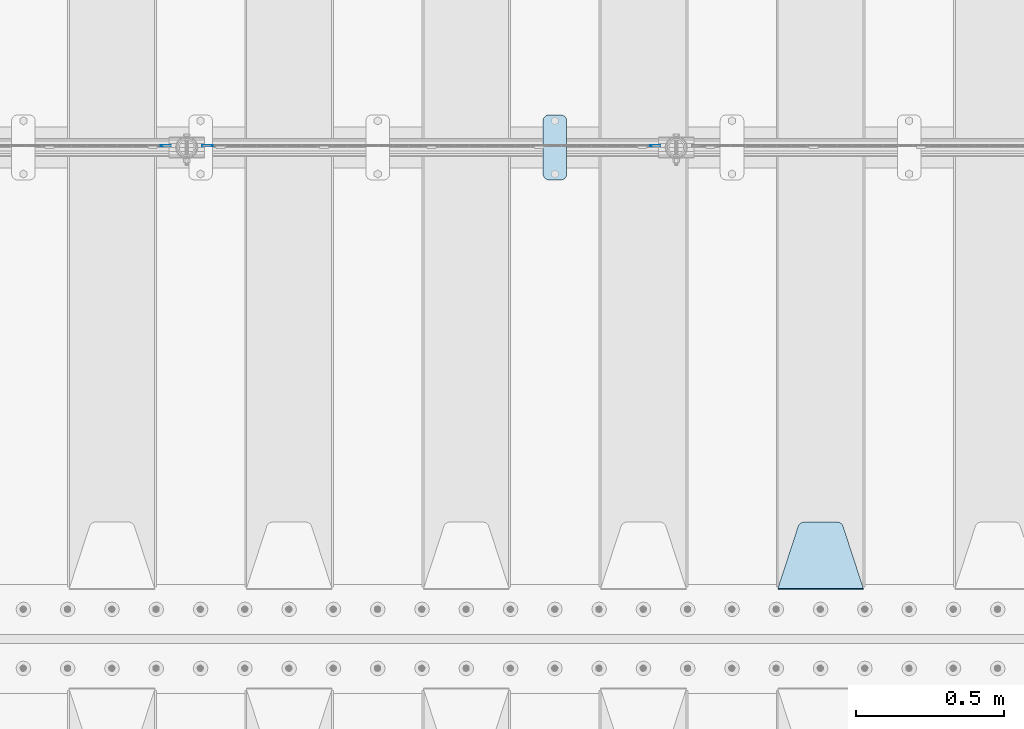
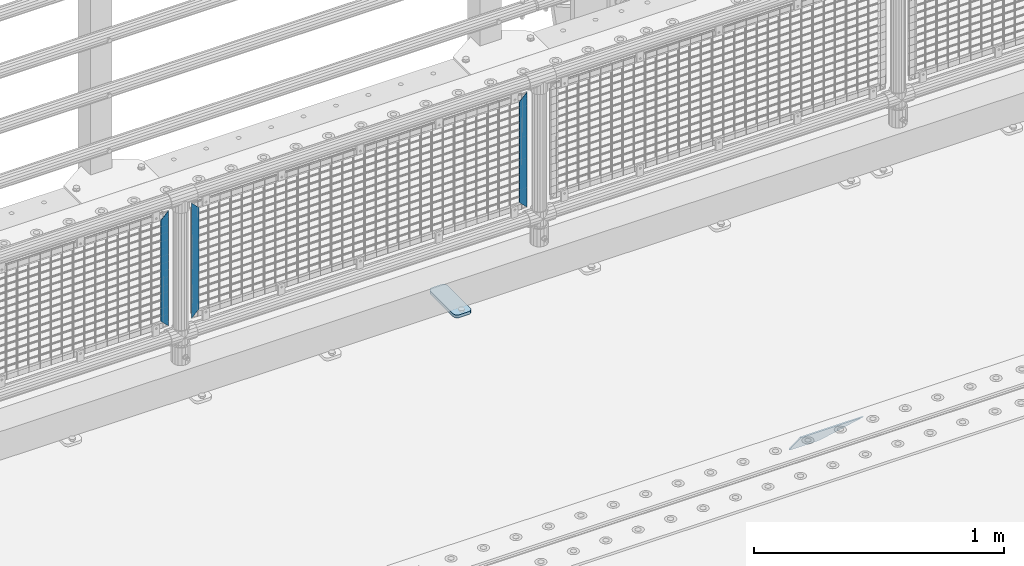
# One storey, part 218 of 240: 5 plates.
"""IFC2X3 building model written with IfcOpenShell, lengths in millimetres."""

from ifc_helpers import new_model, si_unit, frame, origin_with_axes, place, context, subcontext, project, spatial, faceted_brep, material, type_object, element, save


model = new_model("IFC2X3")

# Units and contexts
model_context = context("Model", 3, precision=1e-05, world=origin_with_axes())
body_context = subcontext(model_context, "Body", "Model", "MODEL_VIEW")
ifc_project = project(units=[si_unit("LENGTHUNIT", "METRE", prefix="MILLI"), si_unit("AREAUNIT", "SQUARE_METRE"), si_unit("VOLUMEUNIT", "CUBIC_METRE"), si_unit("MASSUNIT", "GRAM", prefix="KILO"), si_unit("TIMEUNIT", "SECOND"), si_unit("PLANEANGLEUNIT", "RADIAN"), si_unit("SOLIDANGLEUNIT", "STERADIAN"), si_unit("THERMODYNAMICTEMPERATUREUNIT", "DEGREE_CELSIUS"), si_unit("LUMINOUSINTENSITYUNIT", "LUMEN")], contexts=[model_context])

# Site, building, storey
site_placement = place(None, origin_with_axes())
site = spatial("IfcSite", under=ifc_project, at=site_placement, CompositionType="ELEMENT")
building_placement = place(site_placement, origin_with_axes())
building = spatial("IfcBuilding", under=site, at=building_placement, Name="Standard", CompositionType="ELEMENT")
storey_placement = place(building_placement, origin_with_axes())
storey = spatial("IfcBuildingStorey", under=building, at=storey_placement, Name="Undefined", CompositionType="ELEMENT", Elevation=0.0)

# Plates
ifc_material_1 = material(Name="STEEL/S355N")
plate_type_1 = type_object("IfcPlateType", PredefinedType="NOTDEFINED")
plate_1_placement = place(storey_placement, frame((51995.0, 33168.232233047, -1.76776695296758), z_axis=(0.0, 0.707106781186547, -0.707106781186548), x_axis=(-1.0, 0.0, 0.0)))
element("IfcPlate", 1, at=plate_1_placement, inside=storey, type_object=plate_type_1, material=ifc_material_1, context=body_context, shape_type="Brep", body=[
    faceted_brep([(0.0, -2.5, 0.0), (69.345504679477, -2.50000000000364, 300.171731424827), (69.345504679477, 2.49999999999636, 300.171731424827), (0.0, 2.5, 0.0), (70.927406119954, -2.50000000000364, 304.897442415397), (70.927406119954, 2.49999999999636, 304.897442415397), (73.3818627772271, -2.50000000000728, 309.234538108525), (73.3818627772271, 2.49999999999636, 309.234538108529), (76.6187032999587, -2.50000000000728, 313.023683126099), (76.6187032999587, 2.49999999999636, 313.023683126103), (80.5190132705029, -2.50000000000364, 316.125672595368), (80.5190132705029, 2.49999999999636, 316.125672595368), (84.9395038596849, -2.50000000000364, 318.426546230472), (84.9395038596849, 2.49999999999636, 318.426546230472), (89.7177759439219, -2.5, 319.841774983277), (89.7177759439219, 2.49999999999636, 319.841774983273), (94.6782862926484, -2.50000000000364, 320.319366455074), (94.6782862926484, 2.49999999999636, 320.319366455074), (195.321713707352, -2.50000000000364, 320.319366455074), (195.321713707352, 2.49999999999636, 320.319366455074), (200.282224056078, -2.50000000000364, 319.841774983273), (200.282224056078, 2.49999999999636, 319.841774983273), (205.060496140315, -2.50000000000364, 318.426546230472), (205.060496140315, 2.49999999999636, 318.426546230472), (209.480986729497, -2.50000000000364, 316.125672595368), (209.480986729497, 2.49999999999636, 316.125672595368), (213.381296700041, -2.50000000000728, 313.023683126099), (213.381296700041, 2.49999999999272, 313.023683126099), (216.618137222766, -2.50000000000364, 309.234538108522), (216.618137222766, 2.49999999999636, 309.234538108522), (219.072593880039, -2.50000000000364, 304.897442415397), (219.072593880039, 2.49999999999636, 304.897442415397), (220.654495320523, -2.50000000000364, 300.171731424827), (220.654495320523, 2.49999999999636, 300.171731424827), (290.0, -2.50000000000364, -3.63797880709171e-12), (290.0, 2.49999999999636, -3.63797880709171e-12)], [[[0, 1, 2, 3]], [[1, 4, 5, 2]], [[4, 6, 7, 5]], [[6, 8, 9, 7]], [[8, 10, 11, 9]], [[10, 12, 13, 11]], [[12, 14, 15, 13]], [[14, 16, 17, 15]], [[16, 18, 19, 17]], [[18, 20, 21, 19]], [[20, 22, 23, 21]], [[22, 24, 25, 23]], [[24, 26, 27, 25]], [[26, 28, 29, 27]], [[28, 30, 31, 29]], [[30, 32, 33, 31]], [[32, 34, 35, 33]], [[34, 0, 3, 35]], [[5, 7, 9, 11, 13, 15, 17, 19, 21, 23, 25, 27, 29, 31, 33, 35, 3, 2]], [[34, 32, 30, 28, 26, 24, 22, 20, 18, 16, 14, 12, 10, 8, 6, 4, 1, 0]]]),
])
ifc_material_2 = material(Name="STEEL/S355J2")
plate_type_2 = type_object("IfcPlateType", PredefinedType="NOTDEFINED")
plate_2_placement = place(storey_placement, frame((50910.0, 34774.5, 21.0199999999977), z_axis=(1.0, 0.0, 0.0), x_axis=(0.0, -1.0, 0.0)))
element("IfcPlate", 2, at=plate_2_placement, inside=storey, type_object=plate_type_2, material=ifc_material_2, context=body_context, shape_type="Brep", body=[
    faceted_brep([(0.0, -7.0, 20.0), (0.0, -7.0, 60.0), (0.0, 7.0, 60.0), (0.0, 7.0, 20.0), (0.384294391937146, -7.0, 63.9018064403208), (0.384294391937146, 7.0, 63.9018064403208), (1.52240934977453, -7.0, 67.6536686473046), (1.52240934977453, 7.0, 67.6536686473046), (3.37060775394639, -7.0, 71.1114046603907), (3.37060775394639, 7.0, 71.1114046603907), (5.85786437626666, -7.0, 74.1421356237333), (5.85786437626666, 7.0, 74.1421356237333), (8.88859533960931, -7.0, 76.6293922460536), (8.88859533960931, 7.0, 76.6293922460536), (12.3463313526954, -7.0, 78.4775906502255), (12.3463313526954, 7.0, 78.4775906502255), (16.0981935596792, -7.0, 79.6157056080629), (16.0981935596792, 7.0, 79.6157056080629), (20.0, -7.0, 80.0), (20.0, 7.0, 80.0), (200.0, -7.0, 80.0), (200.0, 7.0, 80.0), (203.901806440321, -7.0, 79.6157056080629), (203.901806440321, 7.0, 79.6157056080629), (207.653668647305, -7.0, 78.4775906502255), (207.653668647305, 7.0, 78.4775906502255), (211.111404660391, -7.0, 76.6293922460536), (211.111404660391, 7.0, 76.6293922460536), (214.142135623733, -7.0, 74.1421356237333), (214.142135623733, 7.0, 74.1421356237333), (216.629392246054, -7.0, 71.1114046603907), (216.629392246054, 7.0, 71.1114046603907), (218.477590650225, -7.0, 67.6536686473046), (218.477590650225, 7.0, 67.6536686473046), (219.615705608063, -7.0, 63.9018064403208), (219.615705608063, 7.0, 63.9018064403208), (220.0, -7.0, 60.0), (220.0, 7.0, 60.0), (220.0, -7.0, 20.0), (220.0, 7.0, 20.0), (219.615705608063, -7.0, 16.0981935596792), (219.615705608063, 7.0, 16.0981935596792), (218.477590650225, -7.0, 12.3463313526954), (218.477590650225, 7.0, 12.3463313526954), (216.629392246054, -7.0, 8.88859533960931), (216.629392246054, 7.0, 8.88859533960931), (214.142135623733, -7.0, 5.85786437626666), (214.142135623733, 7.0, 5.85786437626666), (211.111404660391, -7.0, 3.37060775394639), (211.111404660391, 7.0, 3.37060775394639), (207.653668647305, -7.0, 1.52240934977453), (207.653668647305, 7.0, 1.52240934977453), (203.901806440321, -7.0, 0.384294391937146), (203.901806440321, 7.0, 0.384294391937146), (200.0, -7.0, 0.0), (200.0, 7.0, 0.0), (20.0, -7.0, 0.0), (20.0, 7.0, 0.0), (16.0981935596792, -7.0, 0.384294391937146), (16.0981935596792, 7.0, 0.384294391937146), (12.3463313526954, -7.0, 1.52240934977453), (12.3463313526954, 7.0, 1.52240934977453), (8.88859533960931, -7.0, 3.37060775394639), (8.88859533960931, 7.0, 3.37060775394639), (5.85786437626666, -7.0, 5.85786437626666), (5.85786437626666, 7.0, 5.85786437626666), (3.37060775394639, -7.0, 8.88859533960931), (3.37060775394639, 7.0, 8.88859533960931), (1.52240934977453, -7.0, 12.3463313526954), (1.52240934977453, 7.0, 12.3463313526954), (0.384294391937146, -7.0, 16.0981935596792), (0.384294391937146, 7.0, 16.0981935596792)], [[[0, 1, 2, 3]], [[1, 4, 5, 2]], [[4, 6, 7, 5]], [[6, 8, 9, 7]], [[8, 10, 11, 9]], [[10, 12, 13, 11]], [[12, 14, 15, 13]], [[14, 16, 17, 15]], [[16, 18, 19, 17]], [[18, 20, 21, 19]], [[20, 22, 23, 21]], [[22, 24, 25, 23]], [[24, 26, 27, 25]], [[26, 28, 29, 27]], [[28, 30, 31, 29]], [[30, 32, 33, 31]], [[32, 34, 35, 33]], [[34, 36, 37, 35]], [[36, 38, 39, 37]], [[38, 40, 41, 39]], [[40, 42, 43, 41]], [[42, 44, 45, 43]], [[44, 46, 47, 45]], [[46, 48, 49, 47]], [[48, 50, 51, 49]], [[50, 52, 53, 51]], [[52, 54, 55, 53]], [[54, 56, 57, 55]], [[56, 58, 59, 57]], [[58, 60, 61, 59]], [[60, 62, 63, 61]], [[62, 64, 65, 63]], [[64, 66, 67, 65]], [[66, 68, 69, 67]], [[68, 70, 71, 69]], [[70, 0, 3, 71]], [[5, 7, 9, 11, 13, 15, 17, 19, 21, 23, 25, 27, 29, 31, 33, 35, 37, 39, 41, 43, 45, 47, 49, 51, 53, 55, 57, 59, 61, 63, 65, 67, 69, 71, 3, 2]], [[70, 68, 66, 64, 62, 60, 58, 56, 54, 52, 50, 48, 46, 44, 42, 40, 38, 36, 34, 32, 30, 28, 26, 24, 22, 20, 18, 16, 14, 12, 10, 8, 6, 4, 1, 0]]]),
])
ifc_material_3 = material(Name="Misc_Undefined")
plate_type_3 = type_object("IfcPlateType", PredefinedType="NOTDEFINED")
plate_3_placement = place(storey_placement, frame((49791.509713541, 34670.5, 879.519963133601), z_axis=(-0.707008801899317, 0.0, -0.707204746899292), x_axis=(-0.707204746899293, 0.0, 0.707008801899317)))
element("IfcPlate", 3, at=plate_3_placement, inside=storey, type_object=plate_type_3, material=ifc_material_3, context=body_context, shape_type="Brep", body=[
    faceted_brep([(-7.27595761418343e-12, -1.49999999999272, 0.0), (-348.552185058594, -1.5, 348.65502929686), (-348.552185058594, 1.5, 348.65502929686), (0.0, 1.50000000000728, 0.0), (-348.544891357415, -1.5, 398.152496337883), (-348.544891357415, 1.5, 398.152496337883), (49.5043945312573, -1.5, 6.54836185276508e-11), (49.5043945312573, 1.5, 6.54836185276508e-11)], [[[0, 1, 2, 3]], [[1, 4, 5, 2]], [[4, 6, 7, 5]], [[6, 0, 3, 7]], [[5, 7, 3, 2]], [[6, 4, 1, 0]]]),
])
for number, where, z_axis, x_axis in (
    (4, (51272.4996874836, 34670.5, 879.52), (0.707103624179501, 0.0, -0.707109938179499), (0.707109938179525, 0.0, 0.707103624179475)),
    (5, (49614.4996874836, 34670.5, 879.52), (0.707103624179501, 0.0, -0.707109938179499), (0.707109938179525, 0.0, 0.707103624179475)),
):
    element("IfcPlate", number, at=place(storey_placement, frame(where, z_axis=z_axis, x_axis=x_axis)), inside=storey, type_object=plate_type_3, material=ifc_material_3, context=body_context, shape_type="Brep", body=[
        faceted_brep([(-7.27595761418343e-12, -1.49999999999272, 0.0), (-348.605163574233, -1.5, 348.602081298821), (-348.605163574233, 1.5, 348.602081298821), (0.0, 1.50000000000728, 0.0), (-348.605163574226, -1.5, 398.099334716797), (-348.605163574226, 1.5, 398.099334716797), (49.4976959228443, -1.5, -1.09139364212751e-10), (49.4976959228443, 1.5, -1.09139364212751e-10)], [[[0, 1, 2, 3]], [[1, 4, 5, 2]], [[4, 6, 7, 5]], [[6, 0, 3, 7]], [[5, 7, 3, 2]], [[6, 4, 1, 0]]]),
    ])

save(model, "model.ifc")
